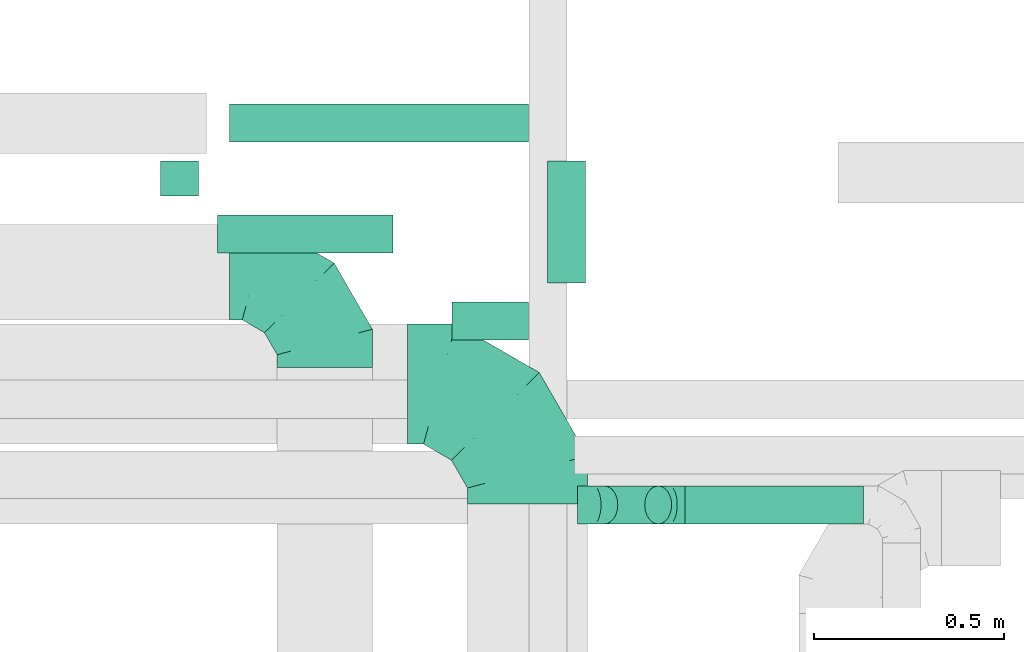
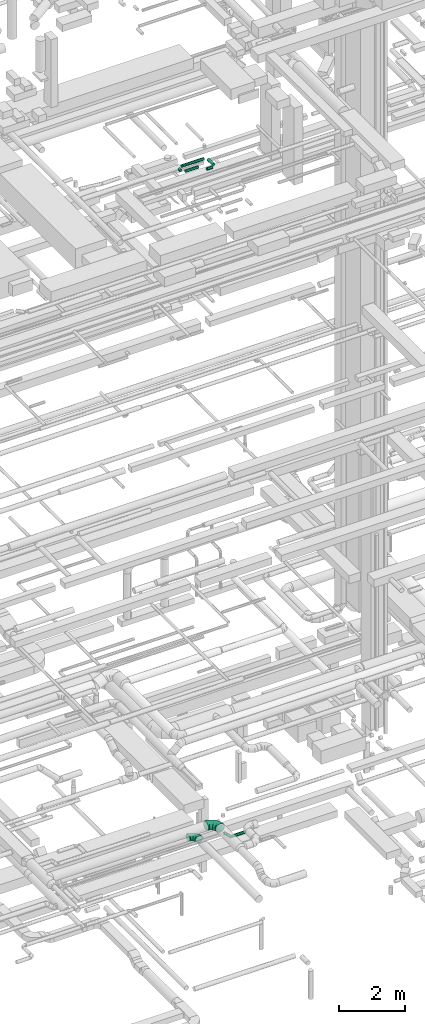
# One storey, part 126 of 337: 7 flow segments, 4 flow fittings.
"""IFC2X3 building model written with IfcOpenShell, lengths in millimetres."""

from ifc_helpers import new_model, entity, si_unit, converted_unit, derived_unit, direction, frame, origin, origin_2d_with_axis, place, context, subcontext, project, spatial, circle, extrude, faceted_brep, source, transform, mapped, material, type_object, type_shapes, element, save


model = new_model("IFC2X3")

# Units and contexts
model_context = context("Model", 3, precision=0.01, world=origin(), true_north=direction((6.12303176911189e-17, 1.0)))
body_context = subcontext(model_context, "Body", "Model", "MODEL_VIEW")
ifc_project = project(units=[si_unit("LENGTHUNIT", "METRE", prefix="MILLI"), si_unit("AREAUNIT", "SQUARE_METRE"), si_unit("VOLUMEUNIT", "CUBIC_METRE"), converted_unit("PLANEANGLEUNIT", "DEGREE", entity("IfcRatioMeasure", 0.0174532925199433), si_unit("PLANEANGLEUNIT", "RADIAN"), dimensions=[0, 0, 0, 0, 0, 0, 0]), si_unit("MASSUNIT", "GRAM", prefix="KILO"), derived_unit("MASSDENSITYUNIT", [(si_unit("MASSUNIT", "GRAM", prefix="KILO"), 1), (si_unit("LENGTHUNIT", "METRE"), -3)]), derived_unit("MOMENTOFINERTIAUNIT", [(si_unit("LENGTHUNIT", "METRE"), 4)]), si_unit("TIMEUNIT", "SECOND"), si_unit("FREQUENCYUNIT", "HERTZ"), si_unit("THERMODYNAMICTEMPERATUREUNIT", "DEGREE_CELSIUS"), derived_unit("THERMALTRANSMITTANCEUNIT", [(si_unit("MASSUNIT", "GRAM", prefix="KILO"), 1), (si_unit("THERMODYNAMICTEMPERATUREUNIT", "KELVIN"), -1), (si_unit("TIMEUNIT", "SECOND"), -3)]), derived_unit("VOLUMETRICFLOWRATEUNIT", [(si_unit("LENGTHUNIT", "METRE"), 3), (si_unit("TIMEUNIT", "SECOND"), -1)]), derived_unit("MASSFLOWRATEUNIT", [(si_unit("MASSUNIT", "GRAM", prefix="KILO"), 1), (si_unit("TIMEUNIT", "SECOND"), -1)]), derived_unit("ROTATIONALFREQUENCYUNIT", [(si_unit("TIMEUNIT", "SECOND"), -1)]), si_unit("ELECTRICCURRENTUNIT", "AMPERE"), si_unit("ELECTRICVOLTAGEUNIT", "VOLT"), si_unit("POWERUNIT", "WATT"), si_unit("FORCEUNIT", "NEWTON", prefix="KILO"), si_unit("ILLUMINANCEUNIT", "LUX"), si_unit("LUMINOUSFLUXUNIT", "LUMEN"), si_unit("LUMINOUSINTENSITYUNIT", "CANDELA"), derived_unit("USERDEFINED", [(si_unit("MASSUNIT", "GRAM", prefix="KILO"), -1), (si_unit("LENGTHUNIT", "METRE"), -2), (si_unit("TIMEUNIT", "SECOND"), 3), (si_unit("LUMINOUSFLUXUNIT", "LUMEN"), 1)]), derived_unit("LINEARVELOCITYUNIT", [(si_unit("LENGTHUNIT", "METRE"), 1), (si_unit("TIMEUNIT", "SECOND"), -1)]), si_unit("PRESSUREUNIT", "PASCAL"), derived_unit("USERDEFINED", [(si_unit("LENGTHUNIT", "METRE"), -2), (si_unit("MASSUNIT", "GRAM", prefix="KILO"), 1), (si_unit("TIMEUNIT", "SECOND"), -2)]), derived_unit("LINEARFORCEUNIT", [(si_unit("MASSUNIT", "GRAM", prefix="KILO"), 1), (si_unit("LENGTHUNIT", "METRE"), 1), (si_unit("TIMEUNIT", "SECOND"), -2), (si_unit("LENGTHUNIT", "METRE"), -1)]), derived_unit("PLANARFORCEUNIT", [(si_unit("MASSUNIT", "GRAM", prefix="KILO"), 1), (si_unit("LENGTHUNIT", "METRE"), 1), (si_unit("TIMEUNIT", "SECOND"), -2), (si_unit("LENGTHUNIT", "METRE"), -2)])], contexts=[model_context])

# Site, building, storey
site_placement = place(None, origin())
site = spatial("IfcSite", under=ifc_project, at=site_placement, CompositionType="ELEMENT")
building_placement = place(site_placement, origin())
building = spatial("IfcBuilding", under=site, at=building_placement, CompositionType="ELEMENT")
storey_placement = place(building_placement, origin())
storey = spatial("IfcBuildingStorey", under=building, at=storey_placement, CompositionType="ELEMENT", Elevation=0.0)

# Flow segments
duct_segment_type = type_object("IfcDuctSegmentType", PredefinedType="NOTDEFINED")
flow_segment_1_placement = place(storey_placement, frame((34568.3, 4720.87, 27548.4)))
element("IfcFlowSegment", 1, at=flow_segment_1_placement, inside=storey, type_object=duct_segment_type, context=body_context, shape_type="SweptSolid", body=[
    extrude(circle(Radius=50.0, at=origin_2d_with_axis()), frame((51.6, 0.0, 51.6), z_axis=(0.0, 1.0, 0.0), x_axis=(1.0, 0.0, 0.0)), (0.0, 0.0, 1.0), 91.5194886207693),
])
flow_segment_2_placement = place(storey_placement, frame((34719.9, 4569.27, 27548.4)))
element("IfcFlowSegment", 2, at=flow_segment_2_placement, inside=storey, type_object=duct_segment_type, context=body_context, shape_type="SweptSolid", body=[
    extrude(circle(Radius=50.0, at=origin_2d_with_axis()), frame((0.0, 51.6, 51.6), z_axis=(1.0, 0.0, 0.0), x_axis=(0.0, -1.0, 0.0)), (0.0, 0.0, 1.0), 460.000000000008),
])
flow_segment_3_placement = place(storey_placement, frame((34750.5, 4860.79, 27548.4)))
element("IfcFlowSegment", 3, at=flow_segment_3_placement, inside=storey, type_object=duct_segment_type, context=body_context, shape_type="SweptSolid", body=[
    extrude(circle(Radius=50.0, at=origin_2d_with_axis()), frame((0.0, 51.6, 51.6), z_axis=(1.0, 0.0, 0.0), x_axis=(0.0, 1.0, 0.0)), (0.0, 0.0, 1.0), 785.000000000012),
])
flow_segment_4_placement = place(storey_placement, frame((35698.16, 3857.96, 2992.34)))
element("IfcFlowSegment", 4, at=flow_segment_4_placement, inside=storey, type_object=duct_segment_type, context=body_context, shape_type="SweptSolid", body=[
    extrude(circle(Radius=50.0, at=origin_2d_with_axis()), frame((178.37, 51.6, 36.95), z_axis=(-0.707106781186546, 0.0, 0.707106781186549), x_axis=(0.0, -1.0, 0.0)), (0.0, 0.0, 1.0), 200.00000000006),
])
flow_segment_5_placement = place(storey_placement, frame((35947.24, 3857.96, 2948.4)))
element("IfcFlowSegment", 5, at=flow_segment_5_placement, inside=storey, type_object=duct_segment_type, context=body_context, shape_type="SweptSolid", body=[
    extrude(circle(Radius=50.0, at=origin_2d_with_axis()), frame((0.0, 51.6, 51.6), z_axis=(1.0, 0.0, 0.0), x_axis=(0.0, 1.0, 0.0)), (0.0, 0.0, 1.0), 468.239563234315),
])
flow_segment_6_placement = place(storey_placement, frame((35583.91, 4492.39, 27548.4)))
element("IfcFlowSegment", 6, at=flow_segment_6_placement, inside=storey, type_object=duct_segment_type, context=body_context, shape_type="SweptSolid", body=[
    extrude(circle(Radius=50.0, at=origin_2d_with_axis()), frame((51.6, 0.0, 51.6), z_axis=(0.0, 1.0, 0.0), x_axis=(-1.0, 0.0, 0.0)), (0.0, 0.0, 1.0), 320.000000000015),
])
flow_segment_7_placement = place(storey_placement, frame((35335.5, 4340.79, 27548.4)))
element("IfcFlowSegment", 7, at=flow_segment_7_placement, inside=storey, type_object=duct_segment_type, context=body_context, shape_type="SweptSolid", body=[
    extrude(circle(Radius=50.0, at=origin_2d_with_axis()), frame((0.0, 51.6, 51.6), z_axis=(1.0, 0.0, 0.0), x_axis=(0.0, 1.0, 0.0)), (0.0, 0.0, 1.0), 200.000000000015),
])

# Flow fittings
ifc_material = material()
duct_fitting_type_1 = type_object("IfcDuctFittingType", PredefinedType="NOTDEFINED", material=ifc_material)
shared_shape_1 = source(origin(), body_context, "Body", "Brep", [
    faceted_brep([(-250.0, 0.0, -125.0), (-250.0, -32.35, -120.74), (-250.0, -62.5, -108.25), (-250.0, -88.39, -88.39), (-250.0, -108.25, -62.5), (-250.0, -120.74, -32.35), (-250.0, -125.0, 0.0), (-250.0, -120.74, 32.35), (-250.0, -108.25, 62.5), (-250.0, -88.39, 88.39), (-250.0, -62.5, 108.25), (-250.0, -32.35, 120.74), (-250.0, 0.0, 125.0), (-250.0, 32.35, 120.74), (-250.0, 62.5, 108.25), (-250.0, 88.39, 88.39), (-250.0, 108.25, 62.5), (-250.0, 120.74, 32.35), (-250.0, 125.0, 0.0), (-250.0, 120.74, -32.35), (-250.0, 108.25, -62.5), (-250.0, 88.39, -88.39), (-250.0, 62.5, -108.25), (-250.0, 32.35, -120.74), (-191.68, 32.35, 120.74), (-199.76, 62.5, 108.25), (-183.01, 0.0, 125.0), (-206.7, 88.39, 88.39), (-215.37, 120.74, 32.35), (-216.51, 125.0, 0.0), (-212.02, 108.25, 62.5), (-212.02, 108.25, -62.5), (-206.7, 88.39, -88.39), (-215.37, 120.74, -32.35), (-191.68, 32.35, -120.74), (-183.01, 0.0, -125.0), (-199.76, 62.5, -108.25), (-174.34, -32.35, -120.74), (-166.27, -62.5, -108.25), (-159.33, -88.39, -88.39), (-154.01, -108.25, -62.5), (-150.66, -120.74, -32.35), (-149.52, -125.0, 0.0), (-150.66, -120.74, 32.35), (-154.01, -108.25, 62.5), (-159.33, -88.39, 88.39), (-166.27, -62.5, 108.25), (-174.34, -32.35, 120.74), (-90.67, 90.67, 120.74), (-112.74, 112.74, 108.25), (-66.99, 66.99, 125.0), (-131.69, 131.69, 88.39), (-146.23, 146.23, 62.5), (-155.38, 155.38, 32.35), (-158.49, 158.49, 0.0), (-155.38, 155.38, -32.35), (-146.23, 146.23, -62.5), (-131.69, 131.69, -88.39), (-90.67, 90.67, -120.74), (-66.99, 66.99, -125.0), (-112.74, 112.74, -108.25), (-43.3, 43.3, -120.74), (-21.23, 21.23, -108.25), (-2.28, 2.28, -88.39), (12.26, -12.26, -62.5), (21.4, -21.4, -32.35), (24.52, -24.52, 0.0), (21.4, -21.4, 32.35), (12.26, -12.26, 62.5), (-2.28, 2.28, 88.39), (-21.23, 21.23, 108.25), (-43.3, 43.3, 120.74), (-32.35, 191.68, 120.74), (-62.5, 199.76, 108.25), (0.0, 183.01, 125.0), (-88.39, 206.7, 88.39), (-108.25, 212.02, 62.5), (-120.74, 215.37, 32.35), (-125.0, 216.51, 0.0), (-120.74, 215.37, -32.35), (-108.25, 212.02, -62.5), (-88.39, 206.7, -88.39), (-32.35, 191.68, -120.74), (0.0, 183.01, -125.0), (-62.5, 199.76, -108.25), (32.35, 174.34, -120.74), (62.5, 166.27, -108.25), (88.39, 159.33, -88.39), (108.25, 154.01, -62.5), (120.74, 150.66, -32.35), (125.0, 149.52, 0.0), (120.74, 150.66, 32.35), (108.25, 154.01, 62.5), (88.39, 159.33, 88.39), (62.5, 166.27, 108.25), (32.35, 174.34, 120.74), (-32.35, 250.0, -120.74), (-62.5, 250.0, -108.25), (-88.39, 250.0, -88.39), (-108.25, 250.0, -62.5), (-120.74, 250.0, -32.35), (-125.0, 250.0, 0.0), (-120.74, 250.0, 32.35), (-108.25, 250.0, 62.5), (-88.39, 250.0, 88.39), (-62.5, 250.0, 108.25), (-32.35, 250.0, 120.74), (0.0, 250.0, 125.0), (32.35, 250.0, 120.74), (62.5, 250.0, 108.25), (88.39, 250.0, 88.39), (108.25, 250.0, 62.5), (120.74, 250.0, 32.35), (125.0, 250.0, 0.0), (120.74, 250.0, -32.35), (108.25, 250.0, -62.5), (88.39, 250.0, -88.39), (62.5, 250.0, -108.25), (32.35, 250.0, -120.74), (0.0, 250.0, -125.0)], [[[0, 1, 2, 3, 4, 5, 6, 7, 8, 9, 10, 11, 12, 13, 14, 15, 16, 17, 18, 19, 20, 21, 22, 23]], [[24, 25, 14, 13]], [[26, 24, 13, 12]], [[14, 25, 27, 15]], [[28, 29, 18, 17]], [[30, 28, 17, 16]], [[15, 27, 30, 16]], [[20, 31, 32, 21]], [[33, 31, 20, 19]], [[18, 29, 33, 19]], [[34, 35, 0, 23]], [[36, 34, 23, 22]], [[21, 32, 36, 22]], [[1, 0, 35, 37]], [[2, 1, 37, 38]], [[38, 39, 3, 2]], [[5, 4, 40, 41]], [[6, 5, 41, 42]], [[39, 40, 4, 3]], [[6, 42, 43, 7]], [[7, 43, 44, 8]], [[8, 44, 45, 9]], [[9, 45, 46, 10]], [[10, 46, 47, 11]], [[26, 12, 11, 47]], [[48, 49, 25, 24]], [[50, 48, 24, 26]], [[27, 25, 49, 51]], [[52, 53, 28, 30]], [[51, 52, 30, 27]], [[29, 28, 53, 54]], [[55, 56, 31, 33]], [[54, 55, 33, 29]], [[32, 31, 56, 57]], [[58, 59, 35, 34]], [[60, 58, 34, 36]], [[57, 60, 36, 32]], [[37, 35, 59, 61]], [[38, 37, 61, 62]], [[39, 38, 62, 63]], [[41, 40, 64, 65]], [[42, 41, 65, 66]], [[63, 64, 40, 39]], [[43, 42, 66, 67]], [[44, 43, 67, 68]], [[68, 69, 45, 44]], [[46, 45, 69, 70]], [[47, 46, 70, 71]], [[26, 47, 71, 50]], [[72, 73, 49, 48]], [[74, 72, 48, 50]], [[51, 49, 73, 75]], [[76, 77, 53, 52]], [[75, 76, 52, 51]], [[54, 53, 77, 78]], [[79, 80, 56, 55]], [[78, 79, 55, 54]], [[57, 56, 80, 81]], [[82, 83, 59, 58]], [[84, 82, 58, 60]], [[81, 84, 60, 57]], [[61, 59, 83, 85]], [[62, 61, 85, 86]], [[63, 62, 86, 87]], [[65, 64, 88, 89]], [[66, 65, 89, 90]], [[87, 88, 64, 63]], [[67, 66, 90, 91]], [[68, 67, 91, 92]], [[92, 93, 69, 68]], [[70, 69, 93, 94]], [[71, 70, 94, 95]], [[50, 71, 95, 74]], [[96, 97, 98, 99, 100, 101, 102, 103, 104, 105, 106, 107, 108, 109, 110, 111, 112, 113, 114, 115, 116, 117, 118, 119]], [[72, 74, 107, 106]], [[73, 72, 106, 105]], [[75, 73, 105, 104]], [[77, 76, 103, 102]], [[78, 77, 102, 101]], [[75, 104, 103, 76]], [[78, 101, 100, 79]], [[79, 100, 99, 80]], [[80, 99, 98, 81]], [[84, 97, 96, 82]], [[82, 96, 119, 83]], [[84, 81, 98, 97]], [[83, 119, 118, 85]], [[85, 118, 117, 86]], [[116, 87, 86, 117]], [[88, 115, 114, 89]], [[89, 114, 113, 90]], [[115, 88, 87, 116]], [[91, 90, 113, 112]], [[92, 91, 112, 111]], [[111, 110, 93, 92]], [[95, 94, 109, 108]], [[74, 95, 108, 107]], [[110, 109, 94, 93]]]),
])
type_shapes(duct_fitting_type_1, [shared_shape_1])
flow_fitting_1_placement = place(storey_placement, frame((35001.01, 4520.47, 3000.0), z_axis=(0.0, 0.0, 1.0), x_axis=(0.0, 1.0, 0.0)))
element("IfcFlowFitting", 8, at=flow_fitting_1_placement, inside=storey, type_object=duct_fitting_type_1, material=ifc_material, context=body_context, shape_type="MappedRepresentation", body=[
    mapped(shared_shape_1, transform((0.0, 0.0, 0.0), scale=1.0)),
])
duct_fitting_type_2 = type_object("IfcDuctFittingType", PredefinedType="NOTDEFINED", material=ifc_material)
shared_shape_2 = source(origin(), body_context, "Body", "Brep", [
    faceted_brep([(-41.42, 0.0, -50.0), (-41.42, -12.94, -48.3), (-41.42, -25.0, -43.3), (-41.42, -35.36, -35.36), (-41.42, -43.3, -25.0), (-41.42, -48.3, -12.94), (-41.42, -50.0, 0.0), (-41.42, -48.3, 12.94), (-41.42, -43.3, 25.0), (-41.42, -35.36, 35.36), (-41.42, -25.0, 43.3), (-41.42, -12.94, 48.3), (-41.42, 0.0, 50.0), (-41.42, 12.94, 48.3), (-41.42, 25.0, 43.3), (-41.42, 35.36, 35.36), (-41.42, 43.3, 25.0), (-41.42, 48.3, 12.94), (-41.42, 50.0, 0.0), (-41.42, 48.3, -12.94), (-41.42, 43.3, -25.0), (-41.42, 35.36, -35.36), (-41.42, 25.0, -43.3), (-41.42, 12.94, -48.3), (-5.36, 12.94, 48.3), (-10.36, 25.0, 43.3), (0.0, 0.0, 50.0), (-14.64, 35.36, 35.36), (-20.0, 48.3, 12.94), (-20.71, 50.0, 0.0), (-17.94, 43.3, 25.0), (-17.94, 43.3, -25.0), (-14.64, 35.36, -35.36), (-20.0, 48.3, -12.94), (-5.36, 12.94, -48.3), (0.0, 0.0, -50.0), (-10.36, 25.0, -43.3), (5.36, -12.94, -48.3), (10.36, -25.0, -43.3), (14.64, -35.36, -35.36), (17.94, -43.3, -25.0), (20.0, -48.3, -12.94), (20.71, -50.0, 0.0), (20.0, -48.3, 12.94), (17.94, -43.3, 25.0), (14.64, -35.36, 35.36), (10.36, -25.0, 43.3), (5.36, -12.94, 48.3), (29.29, 29.29, 50.0), (20.14, 38.44, 48.3), (11.61, 46.97, 43.3), (4.29, 54.29, 35.36), (-1.33, 59.91, 25.0), (-4.86, 63.44, 12.94), (-6.07, 64.64, 0.0), (-4.86, 63.44, -12.94), (-1.33, 59.91, -25.0), (4.29, 54.29, -35.36), (11.61, 46.97, -43.3), (20.14, 38.44, -48.3), (29.29, 29.29, -50.0), (38.44, 20.14, -48.3), (46.97, 11.61, -43.3), (54.29, 4.29, -35.36), (59.91, -1.33, -25.0), (63.44, -4.86, -12.94), (64.64, -6.07, 0.0), (63.44, -4.86, 12.94), (59.91, -1.33, 25.0), (54.29, 4.29, 35.36), (46.97, 11.61, 43.3), (38.44, 20.14, 48.3)], [[[0, 1, 2, 3, 4, 5, 6, 7, 8, 9, 10, 11, 12, 13, 14, 15, 16, 17, 18, 19, 20, 21, 22, 23]], [[24, 25, 14, 13]], [[26, 24, 13, 12]], [[14, 25, 27, 15]], [[28, 29, 18, 17]], [[30, 28, 17, 16]], [[16, 15, 27, 30]], [[20, 31, 32, 21]], [[33, 31, 20, 19]], [[18, 29, 33, 19]], [[34, 35, 0, 23]], [[36, 34, 23, 22]], [[32, 36, 22, 21]], [[1, 0, 35, 37]], [[2, 1, 37, 38]], [[38, 39, 3, 2]], [[5, 4, 40, 41]], [[6, 5, 41, 42]], [[39, 40, 4, 3]], [[6, 42, 43, 7]], [[7, 43, 44, 8]], [[8, 44, 45, 9]], [[9, 45, 46, 10]], [[10, 46, 47, 11]], [[26, 12, 11, 47]], [[24, 26, 48, 49]], [[25, 24, 49, 50]], [[27, 25, 50, 51]], [[28, 30, 52, 53]], [[29, 28, 53, 54]], [[27, 51, 52, 30]], [[29, 54, 55, 33]], [[33, 55, 56, 31]], [[31, 56, 57, 32]], [[36, 58, 59, 34]], [[34, 59, 60, 35]], [[36, 32, 57, 58]], [[61, 62, 38, 37]], [[60, 61, 37, 35]], [[63, 39, 38, 62]], [[40, 64, 65, 41]], [[41, 65, 66, 42]], [[64, 40, 39, 63]], [[43, 42, 66, 67]], [[44, 43, 67, 68]], [[68, 69, 45, 44]], [[47, 46, 70, 71]], [[26, 47, 71, 48]], [[69, 70, 46, 45]], [[59, 58, 57, 56, 55, 54, 53, 52, 51, 50, 49, 48, 71, 70, 69, 68, 67, 66, 65, 64, 63, 62, 61, 60]]]),
])
type_shapes(duct_fitting_type_2, [shared_shape_2])
for number, where, z_axis, x_axis in (
    (9, (35905.82, 3909.56, 3000.0), (0.0, -1.0, 0.0), (0.707106781186493, 0.0, -0.707106781186602)),
    (10, (35705.82, 3909.56, 3200.0), (0.0, -1.0, 0.0), (-0.707106781186493, 0.0, 0.707106781186602)),
):
    element("IfcFlowFitting", number, at=place(storey_placement, frame(where, z_axis=z_axis, x_axis=x_axis)), inside=storey, type_object=duct_fitting_type_2, material=ifc_material, context=body_context, shape_type="MappedRepresentation", body=[
        mapped(shared_shape_2, transform((0.0, 0.0, 0.0), scale=1.0)),
    ])
duct_fitting_type_3 = type_object("IfcDuctFittingType", PredefinedType="NOTDEFINED", material=ifc_material)
shared_shape_3 = source(origin(), body_context, "Body", "Brep", [
    faceted_brep([(-315.0, 0.0, -157.5), (-315.0, -40.76, -152.13), (-315.0, -78.75, -136.4), (-315.0, -111.37, -111.37), (-315.0, -136.4, -78.75), (-315.0, -152.13, -40.76), (-315.0, -157.5, 0.0), (-315.0, -152.13, 40.76), (-315.0, -136.4, 78.75), (-315.0, -111.37, 111.37), (-315.0, -78.75, 136.4), (-315.0, -40.76, 152.13), (-315.0, 0.0, 157.5), (-315.0, 40.76, 152.13), (-315.0, 78.75, 136.4), (-315.0, 111.37, 111.37), (-315.0, 136.4, 78.75), (-315.0, 152.13, 40.76), (-315.0, 157.5, 0.0), (-315.0, 152.13, -40.76), (-315.0, 136.4, -78.75), (-315.0, 111.37, -111.37), (-315.0, 78.75, -136.4), (-315.0, 40.76, -152.13), (-241.52, 40.76, 152.13), (-251.7, 78.75, 136.4), (-230.6, 0.0, 157.5), (-260.44, 111.37, 111.37), (-271.36, 152.13, 40.76), (-272.8, 157.5, 0.0), (-267.14, 136.4, 78.75), (-267.14, 136.4, -78.75), (-260.44, 111.37, -111.37), (-271.36, 152.13, -40.76), (-241.52, 40.76, -152.13), (-230.6, 0.0, -157.5), (-251.7, 78.75, -136.4), (-219.67, -40.76, -152.13), (-209.5, -78.75, -136.4), (-200.75, -111.37, -111.37), (-194.05, -136.4, -78.75), (-189.83, -152.13, -40.76), (-188.39, -157.5, 0.0), (-189.83, -152.13, 40.76), (-194.05, -136.4, 78.75), (-200.75, -111.37, 111.37), (-209.5, -78.75, 136.4), (-219.67, -40.76, 152.13), (-114.25, 114.25, 152.13), (-142.05, 142.05, 136.4), (-84.4, 84.4, 157.5), (-165.93, 165.93, 111.37), (-184.25, 184.25, 78.75), (-195.77, 195.77, 40.76), (-199.7, 199.7, 0.0), (-195.77, 195.77, -40.76), (-184.25, 184.25, -78.75), (-165.93, 165.93, -111.37), (-114.25, 114.25, -152.13), (-84.4, 84.4, -157.5), (-142.05, 142.05, -136.4), (-54.56, 54.56, -152.13), (-26.75, 26.75, -136.4), (-2.88, 2.88, -111.37), (15.45, -15.45, -78.75), (26.97, -26.97, -40.76), (30.89, -30.89, 0.0), (26.97, -26.97, 40.76), (15.45, -15.45, 78.75), (-2.88, 2.88, 111.37), (-26.75, 26.75, 136.4), (-54.56, 54.56, 152.13), (-40.76, 241.52, 152.13), (-78.75, 251.7, 136.4), (0.0, 230.6, 157.5), (-111.37, 260.44, 111.37), (-136.4, 267.14, 78.75), (-152.13, 271.36, 40.76), (-157.5, 272.8, 0.0), (-152.13, 271.36, -40.76), (-136.4, 267.14, -78.75), (-111.37, 260.44, -111.37), (-40.76, 241.52, -152.13), (0.0, 230.6, -157.5), (-78.75, 251.7, -136.4), (40.76, 219.67, -152.13), (78.75, 209.5, -136.4), (111.37, 200.75, -111.37), (136.4, 194.05, -78.75), (152.13, 189.83, -40.76), (157.5, 188.39, 0.0), (152.13, 189.83, 40.76), (136.4, 194.05, 78.75), (111.37, 200.75, 111.37), (78.75, 209.5, 136.4), (40.76, 219.67, 152.13), (-40.76, 315.0, -152.13), (-78.75, 315.0, -136.4), (-111.37, 315.0, -111.37), (-136.4, 315.0, -78.75), (-152.13, 315.0, -40.76), (-157.5, 315.0, 0.0), (-152.13, 315.0, 40.76), (-136.4, 315.0, 78.75), (-111.37, 315.0, 111.37), (-78.75, 315.0, 136.4), (-40.76, 315.0, 152.13), (0.0, 315.0, 157.5), (40.76, 315.0, 152.13), (78.75, 315.0, 136.4), (111.37, 315.0, 111.37), (136.4, 315.0, 78.75), (152.13, 315.0, 40.76), (157.5, 315.0, 0.0), (152.13, 315.0, -40.76), (136.4, 315.0, -78.75), (111.37, 315.0, -111.37), (78.75, 315.0, -136.4), (40.76, 315.0, -152.13), (0.0, 315.0, -157.5)], [[[0, 1, 2, 3, 4, 5, 6, 7, 8, 9, 10, 11, 12, 13, 14, 15, 16, 17, 18, 19, 20, 21, 22, 23]], [[24, 25, 14, 13]], [[26, 24, 13, 12]], [[14, 25, 27, 15]], [[28, 29, 18, 17]], [[30, 28, 17, 16]], [[15, 27, 30, 16]], [[20, 31, 32, 21]], [[33, 31, 20, 19]], [[18, 29, 33, 19]], [[34, 35, 0, 23]], [[36, 34, 23, 22]], [[32, 36, 22, 21]], [[1, 0, 35, 37]], [[2, 1, 37, 38]], [[38, 39, 3, 2]], [[5, 4, 40, 41]], [[6, 5, 41, 42]], [[39, 40, 4, 3]], [[6, 42, 43, 7]], [[7, 43, 44, 8]], [[8, 44, 45, 9]], [[9, 45, 46, 10]], [[10, 46, 47, 11]], [[26, 12, 11, 47]], [[48, 49, 25, 24]], [[50, 48, 24, 26]], [[27, 25, 49, 51]], [[52, 53, 28, 30]], [[51, 52, 30, 27]], [[29, 28, 53, 54]], [[55, 56, 31, 33]], [[54, 55, 33, 29]], [[32, 31, 56, 57]], [[58, 59, 35, 34]], [[60, 58, 34, 36]], [[57, 60, 36, 32]], [[37, 35, 59, 61]], [[38, 37, 61, 62]], [[39, 38, 62, 63]], [[41, 40, 64, 65]], [[42, 41, 65, 66]], [[63, 64, 40, 39]], [[43, 42, 66, 67]], [[44, 43, 67, 68]], [[68, 69, 45, 44]], [[46, 45, 69, 70]], [[47, 46, 70, 71]], [[26, 47, 71, 50]], [[72, 73, 49, 48]], [[74, 72, 48, 50]], [[51, 49, 73, 75]], [[76, 77, 53, 52]], [[75, 76, 52, 51]], [[54, 53, 77, 78]], [[79, 80, 56, 55]], [[78, 79, 55, 54]], [[57, 56, 80, 81]], [[82, 83, 59, 58]], [[84, 82, 58, 60]], [[81, 84, 60, 57]], [[61, 59, 83, 85]], [[62, 61, 85, 86]], [[63, 62, 86, 87]], [[65, 64, 88, 89]], [[66, 65, 89, 90]], [[87, 88, 64, 63]], [[67, 66, 90, 91]], [[68, 67, 91, 92]], [[92, 93, 69, 68]], [[70, 69, 93, 94]], [[71, 70, 94, 95]], [[50, 71, 95, 74]], [[96, 97, 98, 99, 100, 101, 102, 103, 104, 105, 106, 107, 108, 109, 110, 111, 112, 113, 114, 115, 116, 117, 118, 119]], [[106, 105, 73, 72]], [[107, 106, 72, 74]], [[75, 73, 105, 104]], [[77, 76, 103, 102]], [[78, 77, 102, 101]], [[104, 103, 76, 75]], [[78, 101, 100, 79]], [[79, 100, 99, 80]], [[98, 81, 80, 99]], [[84, 97, 96, 82]], [[82, 96, 119, 83]], [[97, 84, 81, 98]], [[83, 119, 118, 85]], [[85, 118, 117, 86]], [[116, 87, 86, 117]], [[88, 115, 114, 89]], [[89, 114, 113, 90]], [[115, 88, 87, 116]], [[91, 90, 113, 112]], [[92, 91, 112, 111]], [[111, 110, 93, 92]], [[95, 94, 109, 108]], [[74, 95, 108, 107]], [[110, 109, 94, 93]]]),
])
type_shapes(duct_fitting_type_3, [shared_shape_3])
flow_fitting_2_placement = place(storey_placement, frame((35533.26, 4226.79, 3450.0), z_axis=(0.0, 0.0, 1.0), x_axis=(0.0, 1.0, 0.0)))
element("IfcFlowFitting", 11, at=flow_fitting_2_placement, inside=storey, type_object=duct_fitting_type_3, material=ifc_material, context=body_context, shape_type="MappedRepresentation", body=[
    mapped(shared_shape_3, transform((0.0, 0.0, 0.0), scale=1.0)),
])

save(model, "model.ifc")
